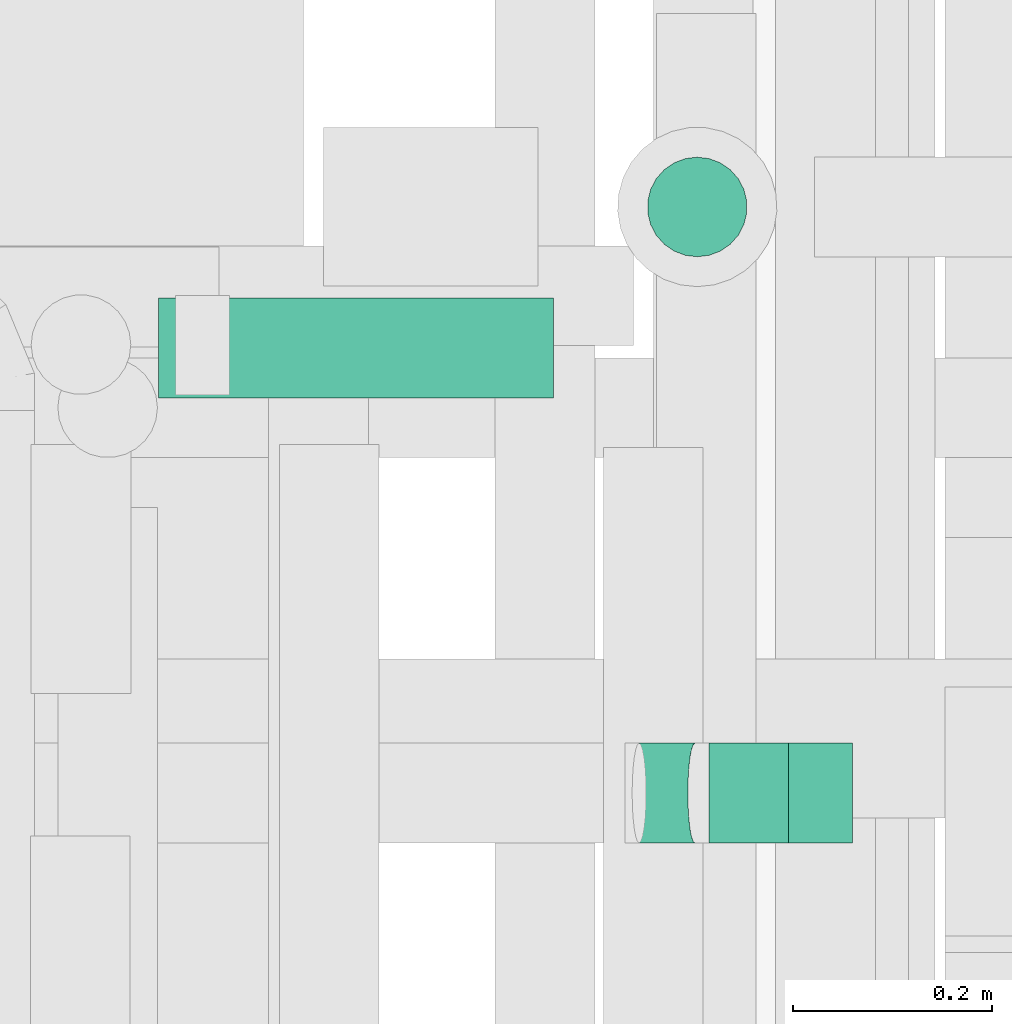
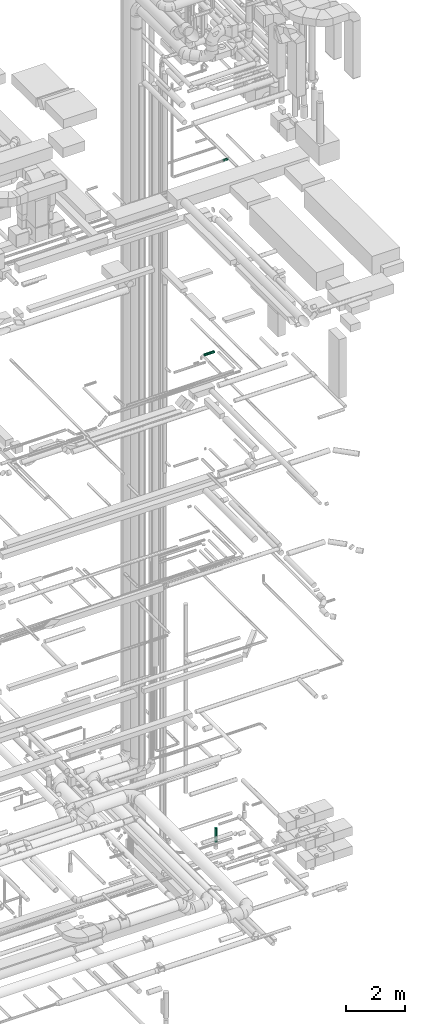
# One storey, part 303 of 337: 4 flow segments, 1 flow fitting.
"""IFC2X3 building model written with IfcOpenShell, lengths in millimetres."""

from ifc_helpers import new_model, entity, si_unit, converted_unit, derived_unit, direction, frame, origin, origin_2d_with_axis, place, context, subcontext, project, spatial, circle, extrude, faceted_brep, source, transform, mapped, material, type_object, type_shapes, element, save


model = new_model("IFC2X3")

# Units and contexts
model_context = context("Model", 3, precision=0.01, world=origin(), true_north=direction((6.12303176911189e-17, 1.0)))
body_context = subcontext(model_context, "Body", "Model", "MODEL_VIEW")
ifc_project = project(units=[si_unit("LENGTHUNIT", "METRE", prefix="MILLI"), si_unit("AREAUNIT", "SQUARE_METRE"), si_unit("VOLUMEUNIT", "CUBIC_METRE"), converted_unit("PLANEANGLEUNIT", "DEGREE", entity("IfcRatioMeasure", 0.0174532925199433), si_unit("PLANEANGLEUNIT", "RADIAN"), dimensions=[0, 0, 0, 0, 0, 0, 0]), si_unit("MASSUNIT", "GRAM", prefix="KILO"), derived_unit("MASSDENSITYUNIT", [(si_unit("MASSUNIT", "GRAM", prefix="KILO"), 1), (si_unit("LENGTHUNIT", "METRE"), -3)]), derived_unit("MOMENTOFINERTIAUNIT", [(si_unit("LENGTHUNIT", "METRE"), 4)]), si_unit("TIMEUNIT", "SECOND"), si_unit("FREQUENCYUNIT", "HERTZ"), si_unit("THERMODYNAMICTEMPERATUREUNIT", "DEGREE_CELSIUS"), derived_unit("THERMALTRANSMITTANCEUNIT", [(si_unit("MASSUNIT", "GRAM", prefix="KILO"), 1), (si_unit("THERMODYNAMICTEMPERATUREUNIT", "KELVIN"), -1), (si_unit("TIMEUNIT", "SECOND"), -3)]), derived_unit("VOLUMETRICFLOWRATEUNIT", [(si_unit("LENGTHUNIT", "METRE"), 3), (si_unit("TIMEUNIT", "SECOND"), -1)]), derived_unit("MASSFLOWRATEUNIT", [(si_unit("MASSUNIT", "GRAM", prefix="KILO"), 1), (si_unit("TIMEUNIT", "SECOND"), -1)]), derived_unit("ROTATIONALFREQUENCYUNIT", [(si_unit("TIMEUNIT", "SECOND"), -1)]), si_unit("ELECTRICCURRENTUNIT", "AMPERE"), si_unit("ELECTRICVOLTAGEUNIT", "VOLT"), si_unit("POWERUNIT", "WATT"), si_unit("FORCEUNIT", "NEWTON", prefix="KILO"), si_unit("ILLUMINANCEUNIT", "LUX"), si_unit("LUMINOUSFLUXUNIT", "LUMEN"), si_unit("LUMINOUSINTENSITYUNIT", "CANDELA"), derived_unit("USERDEFINED", [(si_unit("MASSUNIT", "GRAM", prefix="KILO"), -1), (si_unit("LENGTHUNIT", "METRE"), -2), (si_unit("TIMEUNIT", "SECOND"), 3), (si_unit("LUMINOUSFLUXUNIT", "LUMEN"), 1)]), derived_unit("LINEARVELOCITYUNIT", [(si_unit("LENGTHUNIT", "METRE"), 1), (si_unit("TIMEUNIT", "SECOND"), -1)]), si_unit("PRESSUREUNIT", "PASCAL"), derived_unit("USERDEFINED", [(si_unit("LENGTHUNIT", "METRE"), -2), (si_unit("MASSUNIT", "GRAM", prefix="KILO"), 1), (si_unit("TIMEUNIT", "SECOND"), -2)]), derived_unit("LINEARFORCEUNIT", [(si_unit("MASSUNIT", "GRAM", prefix="KILO"), 1), (si_unit("LENGTHUNIT", "METRE"), 1), (si_unit("TIMEUNIT", "SECOND"), -2), (si_unit("LENGTHUNIT", "METRE"), -1)]), derived_unit("PLANARFORCEUNIT", [(si_unit("MASSUNIT", "GRAM", prefix="KILO"), 1), (si_unit("LENGTHUNIT", "METRE"), 1), (si_unit("TIMEUNIT", "SECOND"), -2), (si_unit("LENGTHUNIT", "METRE"), -2)])], contexts=[model_context])

# Site, building, storey
site_placement = place(None, origin())
site = spatial("IfcSite", under=ifc_project, at=site_placement, CompositionType="ELEMENT")
building_placement = place(site_placement, origin())
building = spatial("IfcBuilding", under=site, at=building_placement, CompositionType="ELEMENT")
storey_placement = place(building_placement, origin())
storey = spatial("IfcBuildingStorey", under=building, at=storey_placement, CompositionType="ELEMENT", Elevation=0.0)

# Flow segments
duct_segment_type = type_object("IfcDuctSegmentType", PredefinedType="NOTDEFINED")
flow_segment_1_placement = place(storey_placement, frame((70607.43, 11705.14, -1243.99)))
element("IfcFlowSegment", 1, at=flow_segment_1_placement, inside=storey, type_object=duct_segment_type, context=body_context, shape_type="SweptSolid", body=[
    extrude(circle(Radius=50.0, at=origin_2d_with_axis()), frame((51.6, 51.6, 0.0), z_axis=(0.0, 0.0, 1.0), x_axis=(0.0, -1.0, 0.0)), (0.0, 0.0, 1.0), 593.991104750001),
])
flow_segment_2_placement = place(storey_placement, frame((70118.57, 11563.6, 19148.4)))
element("IfcFlowSegment", 2, at=flow_segment_2_placement, inside=storey, type_object=duct_segment_type, context=body_context, shape_type="SweptSolid", body=[
    extrude(circle(Radius=50.0, at=origin_2d_with_axis()), frame((0.0, 51.6, 51.6), z_axis=(1.0, 0.0, 0.0), x_axis=(0.0, 1.0, 0.0)), (0.0, 0.0, 1.0), 396.250000000044),
])
flow_segment_3_placement = place(storey_placement, frame((70670.83, 11116.95, 27308.4)))
element("IfcFlowSegment", 3, at=flow_segment_3_placement, inside=storey, type_object=duct_segment_type, context=body_context, shape_type="SweptSolid", body=[
    extrude(circle(Radius=50.0, at=origin_2d_with_axis()), frame((0.0, 51.6, 51.6), z_axis=(1.0, 0.0, 0.0), x_axis=(0.0, 1.0, 0.0)), (0.0, 0.0, 1.0), 80.0343091686532),
])
flow_segment_4_placement = place(storey_placement, frame((70592.09, 11116.95, 27299.91)))
element("IfcFlowSegment", 4, at=flow_segment_4_placement, inside=storey, type_object=duct_segment_type, context=body_context, shape_type="SweptSolid", body=[
    extrude(circle(Radius=50.0, at=origin_2d_with_axis()), frame((8.67, 51.6, 51.09), z_axis=(0.989949425326008, 0.0, 0.141421834582595), x_axis=(0.0, 1.0, 0.0)), (0.0, 0.0, 1.0), 56.4968280095492),
])

# Flow fitting
ifc_material = material()
duct_fitting_type = type_object("IfcDuctFittingType", PredefinedType="NOTDEFINED", material=ifc_material)
shared_shape = source(origin(), body_context, "Body", "Brep", [
    faceted_brep([(20.0, 0.0, -50.0), (20.0, 12.94, -48.3), (20.0, 25.0, -43.3), (20.0, 35.36, -35.36), (20.0, 43.3, -25.0), (20.0, 48.3, -12.94), (20.0, 50.0, 0.0), (20.0, 48.3, 12.94), (20.0, 43.3, 25.0), (20.0, 35.36, 35.36), (20.0, 25.0, 43.3), (20.0, 12.94, 48.3), (20.0, 0.0, 50.0), (20.0, -12.94, 48.3), (20.0, -25.0, 43.3), (20.0, -35.36, 35.36), (20.0, -43.3, 25.0), (20.0, -48.3, 12.94), (20.0, -50.0, 0.0), (20.0, -48.3, -12.94), (20.0, -43.3, -25.0), (20.0, -35.36, -35.36), (20.0, -25.0, -43.3), (20.0, -12.94, -48.3), (0.0, 0.0, 50.0), (-43.9, 0.0, 50.0), (-43.9, -12.94, 48.3), (0.0, -12.94, 48.3), (-43.9, -25.0, 43.3), (0.0, -25.0, 43.3), (0.0, -35.36, 35.36), (-43.9, -35.36, 35.36), (0.0, -43.3, 25.0), (-43.9, -43.3, 25.0), (-43.9, -48.3, 12.94), (0.0, -48.3, 12.94), (-43.9, -50.0, 0.0), (0.0, -50.0, 0.0), (-43.9, -48.3, -12.94), (0.0, -48.3, -12.94), (-43.9, -43.3, -25.0), (0.0, -43.3, -25.0), (0.0, -35.36, -35.36), (-43.9, -35.36, -35.36), (0.0, -25.0, -43.3), (-43.9, -25.0, -43.3), (-43.9, -12.94, -48.3), (0.0, -12.94, -48.3), (-43.9, 0.0, -50.0), (0.0, 0.0, -50.0), (-43.9, 12.94, -48.3), (0.0, 12.94, -48.3), (-43.9, 25.0, -43.3), (0.0, 25.0, -43.3), (0.0, 35.36, -35.36), (-43.9, 35.36, -35.36), (0.0, 43.3, -25.0), (-43.9, 43.3, -25.0), (-43.9, 48.3, -12.94), (0.0, 48.3, -12.94), (-43.9, 50.0, 0.0), (0.0, 50.0, 0.0), (-43.9, 48.3, 12.94), (0.0, 48.3, 12.94), (-43.9, 43.3, 25.0), (0.0, 43.3, 25.0), (0.0, 35.36, 35.36), (-43.9, 35.36, 35.36), (0.0, 25.0, 43.3), (-43.9, 25.0, 43.3), (-43.9, 12.94, 48.3), (0.0, 12.94, 48.3)], [[[0, 1, 2, 3, 4, 5, 6, 7, 8, 9, 10, 11, 12, 13, 14, 15, 16, 17, 18, 19, 20, 21, 22, 23]], [[13, 12, 24, 25, 26, 27]], [[14, 13, 27, 26, 28, 29]], [[30, 15, 14, 29, 28, 31]], [[17, 16, 32, 33, 34, 35]], [[18, 17, 35, 34, 36, 37]], [[32, 16, 15, 30, 31, 33]], [[19, 18, 37, 36, 38, 39]], [[20, 19, 39, 38, 40, 41]], [[42, 21, 20, 41, 40, 43]], [[23, 22, 44, 45, 46, 47]], [[0, 23, 47, 46, 48, 49]], [[44, 22, 21, 42, 43, 45]], [[1, 0, 49, 48, 50, 51]], [[2, 1, 51, 50, 52, 53]], [[54, 3, 2, 53, 52, 55]], [[5, 4, 56, 57, 58, 59]], [[6, 5, 59, 58, 60, 61]], [[56, 4, 3, 54, 55, 57]], [[7, 6, 61, 60, 62, 63]], [[8, 7, 63, 62, 64, 65]], [[66, 9, 8, 65, 64, 67]], [[11, 10, 68, 69, 70, 71]], [[12, 11, 71, 70, 25, 24]], [[68, 10, 9, 66, 67, 69]], [[46, 45, 43, 40, 38, 36, 34, 33, 31, 28, 26, 25, 70, 69, 67, 64, 62, 60, 58, 57, 55, 52, 50, 48]]]),
])
type_shapes(duct_fitting_type, [shared_shape])
flow_fitting_placement = place(storey_placement, frame((70770.86, 11168.54, 27360.0), z_axis=(0.0, 0.0, -1.0), x_axis=(-1.0, 0.0, 0.0)))
element("IfcFlowFitting", 5, at=flow_fitting_placement, inside=storey, type_object=duct_fitting_type, material=ifc_material, context=body_context, shape_type="MappedRepresentation", body=[
    mapped(shared_shape, transform((0.0, 0.0, 0.0), scale=1.0)),
])

save(model, "model.ifc")
